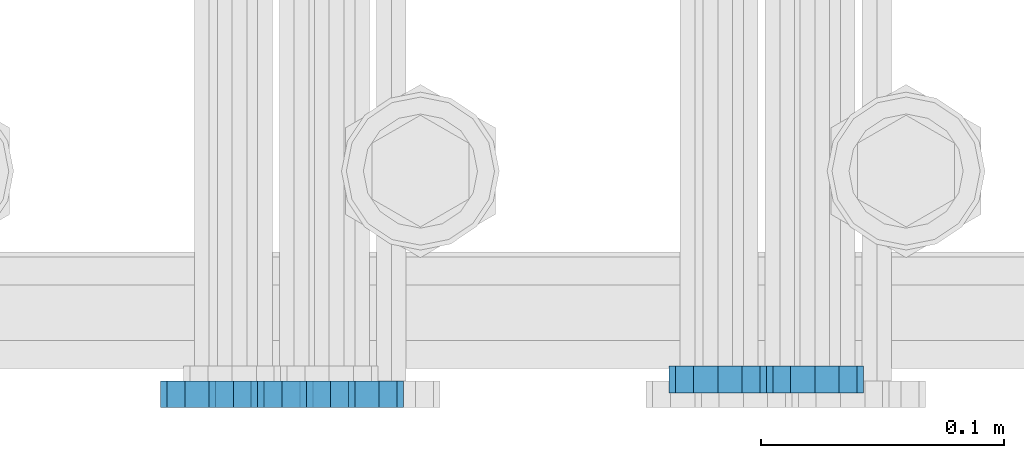
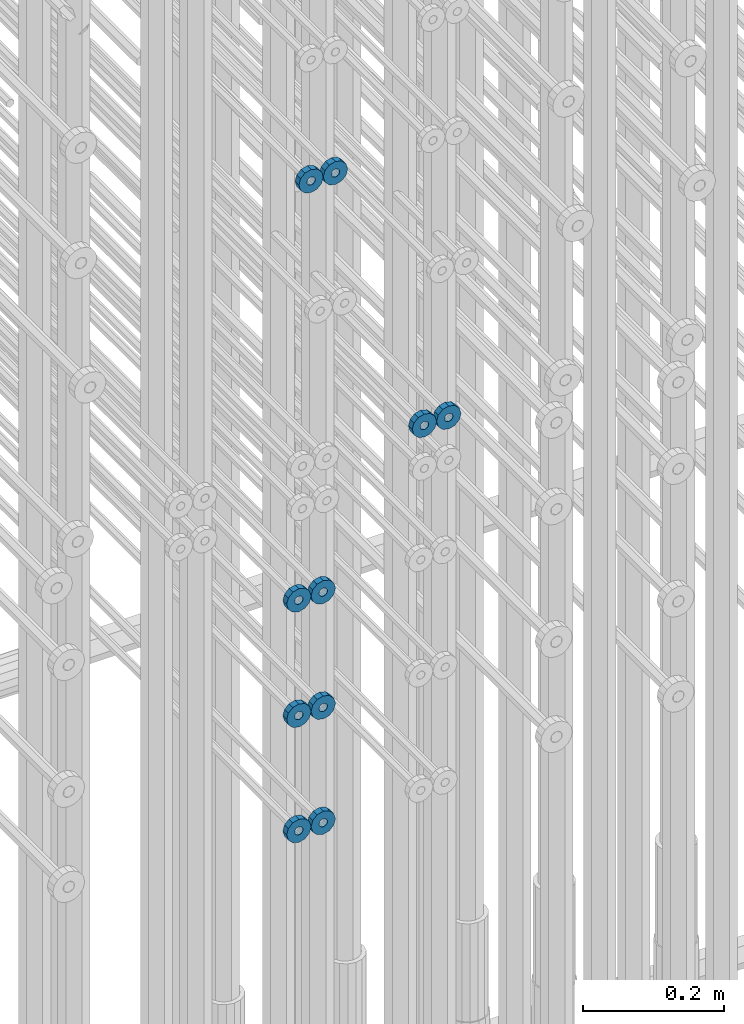
# One storey, part 127 of 177: 10 beams.
"""IFC2X3 building model written with IfcOpenShell, lengths in millimetres."""

from ifc_helpers import new_model, si_unit, frame, origin_with_axes, place, context, subcontext, project, spatial, faceted_brep, material, type_object, element, save


model = new_model("IFC2X3")

# Units and contexts
model_context_1 = context("Model", 3, precision=1e-05, world=origin_with_axes())
model_context_2 = context("Model", 3, precision=1e-05, world=origin_with_axes())
body_context = subcontext(model_context_2, "Body", "Model", "MODEL_VIEW")
ifc_project = project(units=[si_unit("LENGTHUNIT", "METRE", prefix="MILLI"), si_unit("AREAUNIT", "SQUARE_METRE"), si_unit("VOLUMEUNIT", "CUBIC_METRE"), si_unit("MASSUNIT", "GRAM", prefix="KILO"), si_unit("TIMEUNIT", "SECOND"), si_unit("PLANEANGLEUNIT", "RADIAN"), si_unit("SOLIDANGLEUNIT", "STERADIAN"), si_unit("THERMODYNAMICTEMPERATUREUNIT", "DEGREE_CELSIUS"), si_unit("LUMINOUSINTENSITYUNIT", "LUMEN")], contexts=[model_context_1])

# Site, building, storey
site_placement = place(None, origin_with_axes())
site = spatial("IfcSite", under=ifc_project, at=site_placement, CompositionType="ELEMENT")
building_placement = place(site_placement, origin_with_axes())
building = spatial("IfcBuilding", under=site, at=building_placement, Name="Undefined", CompositionType="ELEMENT")
storey_placement = place(building_placement, origin_with_axes())
storey = spatial("IfcBuildingStorey", under=building, at=storey_placement, Name="Undefined", CompositionType="ELEMENT", Elevation=0.0)

# Beams
ifc_material = material(Name="STEEL/Steel_Undefined")
beam_type = type_object("IfcBeamType", PredefinedType="NOTDEFINED")
beam_1_placement = place(storey_placement, frame((2031896.44711753, 6205077.04588021, 20865.9768110314), z_axis=(0.0, 0.0, 1.0), x_axis=(0.0, -1.0, 0.0)))
element("IfcBeam", 1, at=beam_1_placement, inside=storey, type_object=beam_type, material=ifc_material, context=body_context, shape_type="Brep", body=[
    faceted_brep([(-3.63797880709171e-12, -7.0, -2.3283064365387e-10), (-8.62348444298797e-13, -6.06217782649107, 3.5), (10.9999999999964, -6.06217782665044, 3.49999999976717), (10.9999999999964, -7.0, -2.3283064365387e-10), (-3.63797880709171e-12, -3.5, 6.06217782618478), (11.0, -3.5, 6.06217782618478), (-1.72469688859759e-12, 0.0, 7.0), (11.0, 0.0, 6.99999999976717), (-3.63797880709171e-12, 3.5, 6.06217782618478), (11.0, 3.5, 6.06217782618478), (-8.62348444298795e-13, 6.06217782649107, 3.5), (10.9999999999964, 6.06217782665044, 3.49999999976717), (-3.63797880709171e-12, 7.0, -2.3283064365387e-10), (10.9999999999964, 7.0, -2.3283064365387e-10), (8.62348444298797e-13, 6.06217782649107, -3.5), (10.9999999999964, 6.06217782665044, -3.50000000023283), (-3.63797880709171e-12, 3.5, -6.06217782665044), (10.9999999999964, 3.5, -6.06217782665044), (1.72469688859759e-12, -2.72004641033163e-15, -7.0), (10.9999999999964, 0.0, -7.00000000023283), (-3.63797880709171e-12, -3.5, -6.06217782665044), (10.9999999999964, -3.5, -6.06217782665044), (8.62348444298796e-13, -6.06217782649107, -3.5), (10.9999999999964, -6.06217782665044, -3.50000000023283), (0.0, -20.0000000009313, 0.0), (0.0, -17.320508075878, -10.0), (10.9999999999964, -17.320508075878, -10.0000000002328), (10.9999999999964, -20.0, -2.3283064365387e-10), (0.0, -10.0000000009313, -17.3205080756452), (11.0, -10.0, -17.320508075878), (0.0, -1.86264514923096e-09, -19.9999999998836), (10.9999999999964, 0.0, -20.0000000002328), (0.0, 9.99999999906868, -17.3205080755288), (11.0, 10.0, -17.320508075878), (0.0, 17.320508075878, -10.0), (10.9999999999964, 17.320508075878, -10.0000000002328), (0.0, 19.9999999990687, 0.0), (10.9999999999964, 20.0, -2.3283064365387e-10), (0.0, 17.3205080740154, 10.0), (11.0, 17.320508075878, 9.99999999976717), (0.0, 9.99999999906868, 17.3205080757616), (10.9999999999964, 10.0, 17.3205080754124), (0.0, 0.0, 20.0000000001164), (10.9999999999964, 0.0, 19.9999999997672), (0.0, -10.0000000009313, 17.3205080757616), (10.9999999999964, -10.0, 17.3205080754124), (0.0, -17.3205080777407, 10.0000000001164), (11.0, -17.320508075878, 9.99999999976717)], [[[0, 1, 2, 3]], [[1, 4, 5, 2]], [[4, 6, 7, 5]], [[6, 8, 9, 7]], [[8, 10, 11, 9]], [[10, 12, 13, 11]], [[12, 14, 15, 13]], [[14, 16, 17, 15]], [[16, 18, 19, 17]], [[18, 20, 21, 19]], [[20, 22, 23, 21]], [[22, 0, 3, 23]], [[24, 25, 26, 27]], [[25, 28, 29, 26]], [[28, 30, 31, 29]], [[30, 32, 33, 31]], [[32, 34, 35, 33]], [[34, 36, 37, 35]], [[36, 38, 39, 37]], [[38, 40, 41, 39]], [[40, 42, 43, 41]], [[42, 44, 45, 43]], [[44, 46, 47, 45]], [[46, 24, 27, 47]], [[29, 31, 33, 35, 37, 39, 41, 43, 45, 47, 27, 26], [5, 7, 9, 11, 13, 15, 17, 19, 21, 23, 3, 2]], [[46, 44, 42, 40, 38, 36, 34, 32, 30, 28, 25, 24], [22, 20, 18, 16, 14, 12, 10, 8, 6, 4, 1, 0]]]),
])
beam_2_placement = place(storey_placement, frame((2031936.43711754, 6205077.04588021, 20865.9768110316), z_axis=(0.0, 0.0, 1.0), x_axis=(0.0, -1.0, 0.0)))
element("IfcBeam", 2, at=beam_2_placement, inside=storey, type_object=beam_type, material=ifc_material, context=body_context, shape_type="Brep", body=[
    faceted_brep([(-3.63797880709171e-12, -7.0, -2.3283064365387e-10), (-8.62348444298797e-13, -6.06217782649107, 3.5), (10.9999999999964, -6.06217782665044, 3.49999999976717), (10.9999999999964, -7.0, -2.3283064365387e-10), (-3.63797880709171e-12, -3.5, 6.06217782618478), (11.0, -3.5, 6.06217782618478), (-1.72469688859759e-12, 0.0, 7.0), (11.0, 0.0, 6.99999999976717), (-3.63797880709171e-12, 3.5, 6.06217782618478), (11.0, 3.5, 6.06217782618478), (-8.62348444298795e-13, 6.06217782649107, 3.5), (10.9999999999964, 6.06217782665044, 3.49999999976717), (-3.63797880709171e-12, 7.0, -2.3283064365387e-10), (10.9999999999964, 7.0, -2.3283064365387e-10), (8.62348444298797e-13, 6.06217782649107, -3.5), (10.9999999999964, 6.06217782665044, -3.50000000023283), (-3.63797880709171e-12, 3.5, -6.06217782665044), (10.9999999999964, 3.5, -6.06217782665044), (1.72469688859759e-12, -2.72004641033163e-15, -7.0), (10.9999999999964, 0.0, -7.00000000023283), (-3.63797880709171e-12, -3.5, -6.06217782665044), (10.9999999999964, -3.5, -6.06217782665044), (8.62348444298796e-13, -6.06217782649107, -3.5), (10.9999999999964, -6.06217782665044, -3.50000000023283), (0.0, -20.0000000009313, 0.0), (0.0, -17.320508075878, -10.0), (10.9999999999964, -17.320508075878, -10.0000000002328), (10.9999999999964, -20.0, -2.3283064365387e-10), (0.0, -10.0000000009313, -17.3205080756452), (11.0, -10.0, -17.320508075878), (0.0, -1.86264514923096e-09, -19.9999999998836), (10.9999999999964, 0.0, -20.0000000002328), (0.0, 9.99999999906868, -17.3205080755288), (11.0, 10.0, -17.320508075878), (0.0, 17.320508075878, -10.0), (10.9999999999964, 17.320508075878, -10.0000000002328), (0.0, 19.9999999990687, 0.0), (10.9999999999964, 20.0, -2.3283064365387e-10), (0.0, 17.3205080740154, 10.0), (11.0, 17.320508075878, 9.99999999976717), (0.0, 9.99999999906868, 17.3205080757616), (10.9999999999964, 10.0, 17.3205080754124), (0.0, 0.0, 20.0000000001164), (10.9999999999964, 0.0, 19.9999999997672), (0.0, -10.0000000009313, 17.3205080757616), (10.9999999999964, -10.0, 17.3205080754124), (0.0, -17.3205080777407, 10.0000000001164), (11.0, -17.320508075878, 9.99999999976717)], [[[0, 1, 2, 3]], [[1, 4, 5, 2]], [[4, 6, 7, 5]], [[6, 8, 9, 7]], [[8, 10, 11, 9]], [[10, 12, 13, 11]], [[12, 14, 15, 13]], [[14, 16, 17, 15]], [[16, 18, 19, 17]], [[18, 20, 21, 19]], [[20, 22, 23, 21]], [[22, 0, 3, 23]], [[24, 25, 26, 27]], [[25, 28, 29, 26]], [[28, 30, 31, 29]], [[30, 32, 33, 31]], [[32, 34, 35, 33]], [[34, 36, 37, 35]], [[36, 38, 39, 37]], [[38, 40, 41, 39]], [[40, 42, 43, 41]], [[42, 44, 45, 43]], [[44, 46, 47, 45]], [[46, 24, 27, 47]], [[29, 31, 33, 35, 37, 39, 41, 43, 45, 47, 27, 26], [5, 7, 9, 11, 13, 15, 17, 19, 21, 23, 3, 2]], [[46, 44, 42, 40, 38, 36, 34, 32, 30, 28, 25, 24], [22, 20, 18, 16, 14, 12, 10, 8, 6, 4, 1, 0]]]),
])
beam_3_placement = place(storey_placement, frame((2031746.99847313, 6205070.98588033, 21359.9868114202), z_axis=(0.0, 0.0, -1.0), x_axis=(0.0, -1.0, 0.0)))
element("IfcBeam", 3, at=beam_3_placement, inside=storey, type_object=beam_type, material=ifc_material, context=body_context, shape_type="Brep", body=[
    faceted_brep([(-3.63797880709171e-12, -7.0, -2.3283064365387e-10), (-8.62348444298797e-13, -6.06217782649107, 3.5), (10.9999999999964, -6.06217782665044, 3.49999999976717), (10.9999999999964, -7.0, -2.3283064365387e-10), (-3.63797880709171e-12, -3.5, 6.06217782618478), (11.0, -3.5, 6.06217782618478), (-1.72469688859759e-12, 0.0, 7.0), (11.0, 0.0, 6.99999999976717), (-3.63797880709171e-12, 3.5, 6.06217782618478), (11.0, 3.5, 6.06217782618478), (-8.62348444298795e-13, 6.06217782649107, 3.5), (10.9999999999964, 6.06217782665044, 3.49999999976717), (-3.63797880709171e-12, 7.0, -2.3283064365387e-10), (10.9999999999964, 7.0, -2.3283064365387e-10), (8.62348444298797e-13, 6.06217782649107, -3.5), (10.9999999999964, 6.06217782665044, -3.50000000023283), (-3.63797880709171e-12, 3.5, -6.06217782665044), (10.9999999999964, 3.5, -6.06217782665044), (1.72469688859759e-12, -2.72004641033163e-15, -7.0), (10.9999999999964, 0.0, -7.00000000023283), (-3.63797880709171e-12, -3.5, -6.06217782665044), (10.9999999999964, -3.5, -6.06217782665044), (8.62348444298796e-13, -6.06217782649107, -3.5), (10.9999999999964, -6.06217782665044, -3.50000000023283), (0.0, -20.0000000009313, 0.0), (0.0, -17.320508075878, -10.0), (10.9999999999964, -17.320508075878, -10.0000000002328), (10.9999999999964, -20.0, -2.3283064365387e-10), (0.0, -10.0000000009313, -17.3205080756452), (11.0, -10.0, -17.320508075878), (0.0, -1.86264514923096e-09, -19.9999999998836), (10.9999999999964, 0.0, -20.0000000002328), (0.0, 9.99999999906868, -17.3205080755288), (11.0, 10.0, -17.320508075878), (0.0, 17.320508075878, -10.0), (10.9999999999964, 17.320508075878, -10.0000000002328), (0.0, 19.9999999990687, 0.0), (10.9999999999964, 20.0, -2.3283064365387e-10), (0.0, 17.3205080740154, 10.0), (11.0, 17.320508075878, 9.99999999976717), (0.0, 9.99999999906868, 17.3205080757616), (10.9999999999964, 10.0, 17.3205080754124), (0.0, 0.0, 20.0000000001164), (10.9999999999964, 0.0, 19.9999999997672), (0.0, -10.0000000009313, 17.3205080757616), (10.9999999999964, -10.0, 17.3205080754124), (0.0, -17.3205080777407, 10.0000000001164), (11.0, -17.320508075878, 9.99999999976717)], [[[0, 1, 2, 3]], [[1, 4, 5, 2]], [[4, 6, 7, 5]], [[6, 8, 9, 7]], [[8, 10, 11, 9]], [[10, 12, 13, 11]], [[12, 14, 15, 13]], [[14, 16, 17, 15]], [[16, 18, 19, 17]], [[18, 20, 21, 19]], [[20, 22, 23, 21]], [[22, 0, 3, 23]], [[24, 25, 26, 27]], [[25, 28, 29, 26]], [[28, 30, 31, 29]], [[30, 32, 33, 31]], [[32, 34, 35, 33]], [[34, 36, 37, 35]], [[36, 38, 39, 37]], [[38, 40, 41, 39]], [[40, 42, 43, 41]], [[42, 44, 45, 43]], [[44, 46, 47, 45]], [[46, 24, 27, 47]], [[29, 31, 33, 35, 37, 39, 41, 43, 45, 47, 27, 26], [5, 7, 9, 11, 13, 15, 17, 19, 21, 23, 3, 2]], [[46, 44, 42, 40, 38, 36, 34, 32, 30, 28, 25, 24], [22, 20, 18, 16, 14, 12, 10, 8, 6, 4, 1, 0]]]),
])
beam_4_placement = place(storey_placement, frame((2031706.99847313, 6205070.98588033, 21359.9868114202), z_axis=(0.0, 0.0, -1.0), x_axis=(0.0, -1.0, 0.0)))
element("IfcBeam", 4, at=beam_4_placement, inside=storey, type_object=beam_type, material=ifc_material, context=body_context, shape_type="Brep", body=[
    faceted_brep([(-3.63797880709171e-12, -7.0, -2.3283064365387e-10), (-8.62348444298797e-13, -6.06217782649107, 3.5), (10.9999999999964, -6.06217782665044, 3.49999999976717), (10.9999999999964, -7.0, -2.3283064365387e-10), (-3.63797880709171e-12, -3.5, 6.06217782618478), (11.0, -3.5, 6.06217782618478), (-1.72469688859759e-12, 0.0, 7.0), (11.0, 0.0, 6.99999999976717), (-3.63797880709171e-12, 3.5, 6.06217782618478), (11.0, 3.5, 6.06217782618478), (-8.62348444298795e-13, 6.06217782649107, 3.5), (10.9999999999964, 6.06217782665044, 3.49999999976717), (-3.63797880709171e-12, 7.0, -2.3283064365387e-10), (10.9999999999964, 7.0, -2.3283064365387e-10), (8.62348444298797e-13, 6.06217782649107, -3.5), (10.9999999999964, 6.06217782665044, -3.50000000023283), (-3.63797880709171e-12, 3.5, -6.06217782665044), (10.9999999999964, 3.5, -6.06217782665044), (1.72469688859759e-12, -2.72004641033163e-15, -7.0), (10.9999999999964, 0.0, -7.00000000023283), (-3.63797880709171e-12, -3.5, -6.06217782665044), (10.9999999999964, -3.5, -6.06217782665044), (8.62348444298796e-13, -6.06217782649107, -3.5), (10.9999999999964, -6.06217782665044, -3.50000000023283), (0.0, -20.0000000009313, 0.0), (0.0, -17.320508075878, -10.0), (10.9999999999964, -17.320508075878, -10.0000000002328), (10.9999999999964, -20.0, -2.3283064365387e-10), (0.0, -10.0000000009313, -17.3205080756452), (11.0, -10.0, -17.320508075878), (0.0, -1.86264514923096e-09, -19.9999999998836), (10.9999999999964, 0.0, -20.0000000002328), (0.0, 9.99999999906868, -17.3205080755288), (11.0, 10.0, -17.320508075878), (0.0, 17.320508075878, -10.0), (10.9999999999964, 17.320508075878, -10.0000000002328), (0.0, 19.9999999990687, 0.0), (10.9999999999964, 20.0, -2.3283064365387e-10), (0.0, 17.3205080740154, 10.0), (11.0, 17.320508075878, 9.99999999976717), (0.0, 9.99999999906868, 17.3205080757616), (10.9999999999964, 10.0, 17.3205080754124), (0.0, 0.0, 20.0000000001164), (10.9999999999964, 0.0, 19.9999999997672), (0.0, -10.0000000009313, 17.3205080757616), (10.9999999999964, -10.0, 17.3205080754124), (0.0, -17.3205080777407, 10.0000000001164), (11.0, -17.320508075878, 9.99999999976717)], [[[0, 1, 2, 3]], [[1, 4, 5, 2]], [[4, 6, 7, 5]], [[6, 8, 9, 7]], [[8, 10, 11, 9]], [[10, 12, 13, 11]], [[12, 14, 15, 13]], [[14, 16, 17, 15]], [[16, 18, 19, 17]], [[18, 20, 21, 19]], [[20, 22, 23, 21]], [[22, 0, 3, 23]], [[24, 25, 26, 27]], [[25, 28, 29, 26]], [[28, 30, 31, 29]], [[30, 32, 33, 31]], [[32, 34, 35, 33]], [[34, 36, 37, 35]], [[36, 38, 39, 37]], [[38, 40, 41, 39]], [[40, 42, 43, 41]], [[42, 44, 45, 43]], [[44, 46, 47, 45]], [[46, 24, 27, 47]], [[29, 31, 33, 35, 37, 39, 41, 43, 45, 47, 27, 26], [5, 7, 9, 11, 13, 15, 17, 19, 21, 23, 3, 2]], [[46, 44, 42, 40, 38, 36, 34, 32, 30, 28, 25, 24], [22, 20, 18, 16, 14, 12, 10, 8, 6, 4, 1, 0]]]),
])
beam_5_placement = place(storey_placement, frame((2031726.99847313, 6205070.98588034, 20639.9868114202), z_axis=(0.0, 0.0, -1.0), x_axis=(0.0, -1.0, 0.0)))
element("IfcBeam", 5, at=beam_5_placement, inside=storey, type_object=beam_type, material=ifc_material, context=body_context, shape_type="Brep", body=[
    faceted_brep([(-3.63797880709171e-12, -7.0, -2.3283064365387e-10), (-8.62348444298797e-13, -6.06217782649107, 3.5), (10.9999999999964, -6.06217782665044, 3.49999999976717), (10.9999999999964, -7.0, -2.3283064365387e-10), (-3.63797880709171e-12, -3.5, 6.06217782618478), (11.0, -3.5, 6.06217782618478), (-1.72469688859759e-12, 0.0, 7.0), (11.0, 0.0, 6.99999999976717), (-3.63797880709171e-12, 3.5, 6.06217782618478), (11.0, 3.5, 6.06217782618478), (-8.62348444298795e-13, 6.06217782649107, 3.5), (10.9999999999964, 6.06217782665044, 3.49999999976717), (-3.63797880709171e-12, 7.0, -2.3283064365387e-10), (10.9999999999964, 7.0, -2.3283064365387e-10), (8.62348444298797e-13, 6.06217782649107, -3.5), (10.9999999999964, 6.06217782665044, -3.50000000023283), (-3.63797880709171e-12, 3.5, -6.06217782665044), (10.9999999999964, 3.5, -6.06217782665044), (1.72469688859759e-12, -2.72004641033163e-15, -7.0), (10.9999999999964, 0.0, -7.00000000023283), (-3.63797880709171e-12, -3.5, -6.06217782665044), (10.9999999999964, -3.5, -6.06217782665044), (8.62348444298796e-13, -6.06217782649107, -3.5), (10.9999999999964, -6.06217782665044, -3.50000000023283), (0.0, -20.0000000009313, 0.0), (0.0, -17.320508075878, -10.0), (10.9999999999964, -17.320508075878, -10.0000000002328), (10.9999999999964, -20.0, -2.3283064365387e-10), (0.0, -10.0000000009313, -17.3205080756452), (11.0, -10.0, -17.320508075878), (0.0, -1.86264514923096e-09, -19.9999999998836), (10.9999999999964, 0.0, -20.0000000002328), (0.0, 9.99999999906868, -17.3205080755288), (11.0, 10.0, -17.320508075878), (0.0, 17.320508075878, -10.0), (10.9999999999964, 17.320508075878, -10.0000000002328), (0.0, 19.9999999990687, 0.0), (10.9999999999964, 20.0, -2.3283064365387e-10), (0.0, 17.3205080740154, 10.0), (11.0, 17.320508075878, 9.99999999976717), (0.0, 9.99999999906868, 17.3205080757616), (10.9999999999964, 10.0, 17.3205080754124), (0.0, 0.0, 20.0000000001164), (10.9999999999964, 0.0, 19.9999999997672), (0.0, -10.0000000009313, 17.3205080757616), (10.9999999999964, -10.0, 17.3205080754124), (0.0, -17.3205080777407, 10.0000000001164), (11.0, -17.320508075878, 9.99999999976717)], [[[0, 1, 2, 3]], [[1, 4, 5, 2]], [[4, 6, 7, 5]], [[6, 8, 9, 7]], [[8, 10, 11, 9]], [[10, 12, 13, 11]], [[12, 14, 15, 13]], [[14, 16, 17, 15]], [[16, 18, 19, 17]], [[18, 20, 21, 19]], [[20, 22, 23, 21]], [[22, 0, 3, 23]], [[24, 25, 26, 27]], [[25, 28, 29, 26]], [[28, 30, 31, 29]], [[30, 32, 33, 31]], [[32, 34, 35, 33]], [[34, 36, 37, 35]], [[36, 38, 39, 37]], [[38, 40, 41, 39]], [[40, 42, 43, 41]], [[42, 44, 45, 43]], [[44, 46, 47, 45]], [[46, 24, 27, 47]], [[29, 31, 33, 35, 37, 39, 41, 43, 45, 47, 27, 26], [5, 7, 9, 11, 13, 15, 17, 19, 21, 23, 3, 2]], [[46, 44, 42, 40, 38, 36, 34, 32, 30, 28, 25, 24], [22, 20, 18, 16, 14, 12, 10, 8, 6, 4, 1, 0]]]),
])
beam_6_placement = place(storey_placement, frame((2031686.99847313, 6205070.98588034, 20639.9868114202), z_axis=(0.0, 0.0, -1.0), x_axis=(0.0, -1.0, 0.0)))
element("IfcBeam", 6, at=beam_6_placement, inside=storey, type_object=beam_type, material=ifc_material, context=body_context, shape_type="Brep", body=[
    faceted_brep([(-3.63797880709171e-12, -7.0, -2.3283064365387e-10), (-8.62348444298797e-13, -6.06217782649107, 3.5), (10.9999999999964, -6.06217782665044, 3.49999999976717), (10.9999999999964, -7.0, -2.3283064365387e-10), (-3.63797880709171e-12, -3.5, 6.06217782618478), (11.0, -3.5, 6.06217782618478), (-1.72469688859759e-12, 0.0, 7.0), (11.0, 0.0, 6.99999999976717), (-3.63797880709171e-12, 3.5, 6.06217782618478), (11.0, 3.5, 6.06217782618478), (-8.62348444298795e-13, 6.06217782649107, 3.5), (10.9999999999964, 6.06217782665044, 3.49999999976717), (-3.63797880709171e-12, 7.0, -2.3283064365387e-10), (10.9999999999964, 7.0, -2.3283064365387e-10), (8.62348444298797e-13, 6.06217782649107, -3.5), (10.9999999999964, 6.06217782665044, -3.50000000023283), (-3.63797880709171e-12, 3.5, -6.06217782665044), (10.9999999999964, 3.5, -6.06217782665044), (1.72469688859759e-12, -2.72004641033163e-15, -7.0), (10.9999999999964, 0.0, -7.00000000023283), (-3.63797880709171e-12, -3.5, -6.06217782665044), (10.9999999999964, -3.5, -6.06217782665044), (8.62348444298796e-13, -6.06217782649107, -3.5), (10.9999999999964, -6.06217782665044, -3.50000000023283), (0.0, -20.0000000009313, 0.0), (0.0, -17.320508075878, -10.0), (10.9999999999964, -17.320508075878, -10.0000000002328), (10.9999999999964, -20.0, -2.3283064365387e-10), (0.0, -10.0000000009313, -17.3205080756452), (11.0, -10.0, -17.320508075878), (0.0, -1.86264514923096e-09, -19.9999999998836), (10.9999999999964, 0.0, -20.0000000002328), (0.0, 9.99999999906868, -17.3205080755288), (11.0, 10.0, -17.320508075878), (0.0, 17.320508075878, -10.0), (10.9999999999964, 17.320508075878, -10.0000000002328), (0.0, 19.9999999990687, 0.0), (10.9999999999964, 20.0, -2.3283064365387e-10), (0.0, 17.3205080740154, 10.0), (11.0, 17.320508075878, 9.99999999976717), (0.0, 9.99999999906868, 17.3205080757616), (10.9999999999964, 10.0, 17.3205080754124), (0.0, 0.0, 20.0000000001164), (10.9999999999964, 0.0, 19.9999999997672), (0.0, -10.0000000009313, 17.3205080757616), (10.9999999999964, -10.0, 17.3205080754124), (0.0, -17.3205080777407, 10.0000000001164), (11.0, -17.320508075878, 9.99999999976717)], [[[0, 1, 2, 3]], [[1, 4, 5, 2]], [[4, 6, 7, 5]], [[6, 8, 9, 7]], [[8, 10, 11, 9]], [[10, 12, 13, 11]], [[12, 14, 15, 13]], [[14, 16, 17, 15]], [[16, 18, 19, 17]], [[18, 20, 21, 19]], [[20, 22, 23, 21]], [[22, 0, 3, 23]], [[24, 25, 26, 27]], [[25, 28, 29, 26]], [[28, 30, 31, 29]], [[30, 32, 33, 31]], [[32, 34, 35, 33]], [[34, 36, 37, 35]], [[36, 38, 39, 37]], [[38, 40, 41, 39]], [[40, 42, 43, 41]], [[42, 44, 45, 43]], [[44, 46, 47, 45]], [[46, 24, 27, 47]], [[29, 31, 33, 35, 37, 39, 41, 43, 45, 47, 27, 26], [5, 7, 9, 11, 13, 15, 17, 19, 21, 23, 3, 2]], [[46, 44, 42, 40, 38, 36, 34, 32, 30, 28, 25, 24], [22, 20, 18, 16, 14, 12, 10, 8, 6, 4, 1, 0]]]),
])
beam_7_placement = place(storey_placement, frame((2031726.99847313, 6205070.98588034, 20439.9868114202), z_axis=(0.0, 0.0, -1.0), x_axis=(0.0, -1.0, 0.0)))
element("IfcBeam", 7, at=beam_7_placement, inside=storey, type_object=beam_type, material=ifc_material, context=body_context, shape_type="Brep", body=[
    faceted_brep([(-3.63797880709171e-12, -7.0, -2.3283064365387e-10), (-8.62348444298797e-13, -6.06217782649107, 3.5), (10.9999999999964, -6.06217782665044, 3.49999999976717), (10.9999999999964, -7.0, -2.3283064365387e-10), (-3.63797880709171e-12, -3.5, 6.06217782618478), (11.0, -3.5, 6.06217782618478), (-1.72469688859759e-12, 0.0, 7.0), (11.0, 0.0, 6.99999999976717), (-3.63797880709171e-12, 3.5, 6.06217782618478), (11.0, 3.5, 6.06217782618478), (-8.62348444298795e-13, 6.06217782649107, 3.5), (10.9999999999964, 6.06217782665044, 3.49999999976717), (-3.63797880709171e-12, 7.0, -2.3283064365387e-10), (10.9999999999964, 7.0, -2.3283064365387e-10), (8.62348444298797e-13, 6.06217782649107, -3.5), (10.9999999999964, 6.06217782665044, -3.50000000023283), (-3.63797880709171e-12, 3.5, -6.06217782665044), (10.9999999999964, 3.5, -6.06217782665044), (1.72469688859759e-12, -2.72004641033163e-15, -7.0), (10.9999999999964, 0.0, -7.00000000023283), (-3.63797880709171e-12, -3.5, -6.06217782665044), (10.9999999999964, -3.5, -6.06217782665044), (8.62348444298796e-13, -6.06217782649107, -3.5), (10.9999999999964, -6.06217782665044, -3.50000000023283), (0.0, -20.0000000009313, 0.0), (0.0, -17.320508075878, -10.0), (10.9999999999964, -17.320508075878, -10.0000000002328), (10.9999999999964, -20.0, -2.3283064365387e-10), (0.0, -10.0000000009313, -17.3205080756452), (11.0, -10.0, -17.320508075878), (0.0, -1.86264514923096e-09, -19.9999999998836), (10.9999999999964, 0.0, -20.0000000002328), (0.0, 9.99999999906868, -17.3205080755288), (11.0, 10.0, -17.320508075878), (0.0, 17.320508075878, -10.0), (10.9999999999964, 17.320508075878, -10.0000000002328), (0.0, 19.9999999990687, 0.0), (10.9999999999964, 20.0, -2.3283064365387e-10), (0.0, 17.3205080740154, 10.0), (11.0, 17.320508075878, 9.99999999976717), (0.0, 9.99999999906868, 17.3205080757616), (10.9999999999964, 10.0, 17.3205080754124), (0.0, 0.0, 20.0000000001164), (10.9999999999964, 0.0, 19.9999999997672), (0.0, -10.0000000009313, 17.3205080757616), (10.9999999999964, -10.0, 17.3205080754124), (0.0, -17.3205080777407, 10.0000000001164), (11.0, -17.320508075878, 9.99999999976717)], [[[0, 1, 2, 3]], [[1, 4, 5, 2]], [[4, 6, 7, 5]], [[6, 8, 9, 7]], [[8, 10, 11, 9]], [[10, 12, 13, 11]], [[12, 14, 15, 13]], [[14, 16, 17, 15]], [[16, 18, 19, 17]], [[18, 20, 21, 19]], [[20, 22, 23, 21]], [[22, 0, 3, 23]], [[24, 25, 26, 27]], [[25, 28, 29, 26]], [[28, 30, 31, 29]], [[30, 32, 33, 31]], [[32, 34, 35, 33]], [[34, 36, 37, 35]], [[36, 38, 39, 37]], [[38, 40, 41, 39]], [[40, 42, 43, 41]], [[42, 44, 45, 43]], [[44, 46, 47, 45]], [[46, 24, 27, 47]], [[29, 31, 33, 35, 37, 39, 41, 43, 45, 47, 27, 26], [5, 7, 9, 11, 13, 15, 17, 19, 21, 23, 3, 2]], [[46, 44, 42, 40, 38, 36, 34, 32, 30, 28, 25, 24], [22, 20, 18, 16, 14, 12, 10, 8, 6, 4, 1, 0]]]),
])
beam_8_placement = place(storey_placement, frame((2031686.99847313, 6205070.98588034, 20439.9868114202), z_axis=(0.0, 0.0, -1.0), x_axis=(0.0, -1.0, 0.0)))
element("IfcBeam", 8, at=beam_8_placement, inside=storey, type_object=beam_type, material=ifc_material, context=body_context, shape_type="Brep", body=[
    faceted_brep([(-3.63797880709171e-12, -7.0, -2.3283064365387e-10), (-8.62348444298797e-13, -6.06217782649107, 3.5), (10.9999999999964, -6.06217782665044, 3.49999999976717), (10.9999999999964, -7.0, -2.3283064365387e-10), (-3.63797880709171e-12, -3.5, 6.06217782618478), (11.0, -3.5, 6.06217782618478), (-1.72469688859759e-12, 0.0, 7.0), (11.0, 0.0, 6.99999999976717), (-3.63797880709171e-12, 3.5, 6.06217782618478), (11.0, 3.5, 6.06217782618478), (-8.62348444298795e-13, 6.06217782649107, 3.5), (10.9999999999964, 6.06217782665044, 3.49999999976717), (-3.63797880709171e-12, 7.0, -2.3283064365387e-10), (10.9999999999964, 7.0, -2.3283064365387e-10), (8.62348444298797e-13, 6.06217782649107, -3.5), (10.9999999999964, 6.06217782665044, -3.50000000023283), (-3.63797880709171e-12, 3.5, -6.06217782665044), (10.9999999999964, 3.5, -6.06217782665044), (1.72469688859759e-12, -2.72004641033163e-15, -7.0), (10.9999999999964, 0.0, -7.00000000023283), (-3.63797880709171e-12, -3.5, -6.06217782665044), (10.9999999999964, -3.5, -6.06217782665044), (8.62348444298796e-13, -6.06217782649107, -3.5), (10.9999999999964, -6.06217782665044, -3.50000000023283), (0.0, -20.0000000009313, 0.0), (0.0, -17.320508075878, -10.0), (10.9999999999964, -17.320508075878, -10.0000000002328), (10.9999999999964, -20.0, -2.3283064365387e-10), (0.0, -10.0000000009313, -17.3205080756452), (11.0, -10.0, -17.320508075878), (0.0, -1.86264514923096e-09, -19.9999999998836), (10.9999999999964, 0.0, -20.0000000002328), (0.0, 9.99999999906868, -17.3205080755288), (11.0, 10.0, -17.320508075878), (0.0, 17.320508075878, -10.0), (10.9999999999964, 17.320508075878, -10.0000000002328), (0.0, 19.9999999990687, 0.0), (10.9999999999964, 20.0, -2.3283064365387e-10), (0.0, 17.3205080740154, 10.0), (11.0, 17.320508075878, 9.99999999976717), (0.0, 9.99999999906868, 17.3205080757616), (10.9999999999964, 10.0, 17.3205080754124), (0.0, 0.0, 20.0000000001164), (10.9999999999964, 0.0, 19.9999999997672), (0.0, -10.0000000009313, 17.3205080757616), (10.9999999999964, -10.0, 17.3205080754124), (0.0, -17.3205080777407, 10.0000000001164), (11.0, -17.320508075878, 9.99999999976717)], [[[0, 1, 2, 3]], [[1, 4, 5, 2]], [[4, 6, 7, 5]], [[6, 8, 9, 7]], [[8, 10, 11, 9]], [[10, 12, 13, 11]], [[12, 14, 15, 13]], [[14, 16, 17, 15]], [[16, 18, 19, 17]], [[18, 20, 21, 19]], [[20, 22, 23, 21]], [[22, 0, 3, 23]], [[24, 25, 26, 27]], [[25, 28, 29, 26]], [[28, 30, 31, 29]], [[30, 32, 33, 31]], [[32, 34, 35, 33]], [[34, 36, 37, 35]], [[36, 38, 39, 37]], [[38, 40, 41, 39]], [[40, 42, 43, 41]], [[42, 44, 45, 43]], [[44, 46, 47, 45]], [[46, 24, 27, 47]], [[29, 31, 33, 35, 37, 39, 41, 43, 45, 47, 27, 26], [5, 7, 9, 11, 13, 15, 17, 19, 21, 23, 3, 2]], [[46, 44, 42, 40, 38, 36, 34, 32, 30, 28, 25, 24], [22, 20, 18, 16, 14, 12, 10, 8, 6, 4, 1, 0]]]),
])
beam_9_placement = place(storey_placement, frame((2031726.99847313, 6205070.98588034, 20239.9868114202), z_axis=(0.0, 0.0, -1.0), x_axis=(0.0, -1.0, 0.0)))
element("IfcBeam", 9, at=beam_9_placement, inside=storey, type_object=beam_type, material=ifc_material, context=body_context, shape_type="Brep", body=[
    faceted_brep([(-3.63797880709171e-12, -7.0, -2.3283064365387e-10), (-8.62348444298797e-13, -6.06217782649107, 3.5), (10.9999999999964, -6.06217782665044, 3.49999999976717), (10.9999999999964, -7.0, -2.3283064365387e-10), (-3.63797880709171e-12, -3.5, 6.06217782618478), (11.0, -3.5, 6.06217782618478), (-1.72469688859759e-12, 0.0, 7.0), (11.0, 0.0, 6.99999999976717), (-3.63797880709171e-12, 3.5, 6.06217782618478), (11.0, 3.5, 6.06217782618478), (-8.62348444298795e-13, 6.06217782649107, 3.5), (10.9999999999964, 6.06217782665044, 3.49999999976717), (-3.63797880709171e-12, 7.0, -2.3283064365387e-10), (10.9999999999964, 7.0, -2.3283064365387e-10), (8.62348444298797e-13, 6.06217782649107, -3.5), (10.9999999999964, 6.06217782665044, -3.50000000023283), (-3.63797880709171e-12, 3.5, -6.06217782665044), (10.9999999999964, 3.5, -6.06217782665044), (1.72469688859759e-12, -2.72004641033163e-15, -7.0), (10.9999999999964, 0.0, -7.00000000023283), (-3.63797880709171e-12, -3.5, -6.06217782665044), (10.9999999999964, -3.5, -6.06217782665044), (8.62348444298796e-13, -6.06217782649107, -3.5), (10.9999999999964, -6.06217782665044, -3.50000000023283), (0.0, -20.0000000009313, 0.0), (0.0, -17.320508075878, -10.0), (10.9999999999964, -17.320508075878, -10.0000000002328), (10.9999999999964, -20.0, -2.3283064365387e-10), (0.0, -10.0000000009313, -17.3205080756452), (11.0, -10.0, -17.320508075878), (0.0, -1.86264514923096e-09, -19.9999999998836), (10.9999999999964, 0.0, -20.0000000002328), (0.0, 9.99999999906868, -17.3205080755288), (11.0, 10.0, -17.320508075878), (0.0, 17.320508075878, -10.0), (10.9999999999964, 17.320508075878, -10.0000000002328), (0.0, 19.9999999990687, 0.0), (10.9999999999964, 20.0, -2.3283064365387e-10), (0.0, 17.3205080740154, 10.0), (11.0, 17.320508075878, 9.99999999976717), (0.0, 9.99999999906868, 17.3205080757616), (10.9999999999964, 10.0, 17.3205080754124), (0.0, 0.0, 20.0000000001164), (10.9999999999964, 0.0, 19.9999999997672), (0.0, -10.0000000009313, 17.3205080757616), (10.9999999999964, -10.0, 17.3205080754124), (0.0, -17.3205080777407, 10.0000000001164), (11.0, -17.320508075878, 9.99999999976717)], [[[0, 1, 2, 3]], [[1, 4, 5, 2]], [[4, 6, 7, 5]], [[6, 8, 9, 7]], [[8, 10, 11, 9]], [[10, 12, 13, 11]], [[12, 14, 15, 13]], [[14, 16, 17, 15]], [[16, 18, 19, 17]], [[18, 20, 21, 19]], [[20, 22, 23, 21]], [[22, 0, 3, 23]], [[24, 25, 26, 27]], [[25, 28, 29, 26]], [[28, 30, 31, 29]], [[30, 32, 33, 31]], [[32, 34, 35, 33]], [[34, 36, 37, 35]], [[36, 38, 39, 37]], [[38, 40, 41, 39]], [[40, 42, 43, 41]], [[42, 44, 45, 43]], [[44, 46, 47, 45]], [[46, 24, 27, 47]], [[29, 31, 33, 35, 37, 39, 41, 43, 45, 47, 27, 26], [5, 7, 9, 11, 13, 15, 17, 19, 21, 23, 3, 2]], [[46, 44, 42, 40, 38, 36, 34, 32, 30, 28, 25, 24], [22, 20, 18, 16, 14, 12, 10, 8, 6, 4, 1, 0]]]),
])
beam_10_placement = place(storey_placement, frame((2031686.99847313, 6205070.98588034, 20239.9868114202), z_axis=(0.0, 0.0, -1.0), x_axis=(0.0, -1.0, 0.0)))
element("IfcBeam", 10, at=beam_10_placement, inside=storey, type_object=beam_type, material=ifc_material, context=body_context, shape_type="Brep", body=[
    faceted_brep([(-3.63797880709171e-12, -7.0, -2.3283064365387e-10), (-8.62348444298797e-13, -6.06217782649107, 3.5), (10.9999999999964, -6.06217782665044, 3.49999999976717), (10.9999999999964, -7.0, -2.3283064365387e-10), (-3.63797880709171e-12, -3.5, 6.06217782618478), (11.0, -3.5, 6.06217782618478), (-1.72469688859759e-12, 0.0, 7.0), (11.0, 0.0, 6.99999999976717), (-3.63797880709171e-12, 3.5, 6.06217782618478), (11.0, 3.5, 6.06217782618478), (-8.62348444298795e-13, 6.06217782649107, 3.5), (10.9999999999964, 6.06217782665044, 3.49999999976717), (-3.63797880709171e-12, 7.0, -2.3283064365387e-10), (10.9999999999964, 7.0, -2.3283064365387e-10), (8.62348444298797e-13, 6.06217782649107, -3.5), (10.9999999999964, 6.06217782665044, -3.50000000023283), (-3.63797880709171e-12, 3.5, -6.06217782665044), (10.9999999999964, 3.5, -6.06217782665044), (1.72469688859759e-12, -2.72004641033163e-15, -7.0), (10.9999999999964, 0.0, -7.00000000023283), (-3.63797880709171e-12, -3.5, -6.06217782665044), (10.9999999999964, -3.5, -6.06217782665044), (8.62348444298796e-13, -6.06217782649107, -3.5), (10.9999999999964, -6.06217782665044, -3.50000000023283), (0.0, -20.0000000009313, 0.0), (0.0, -17.320508075878, -10.0), (10.9999999999964, -17.320508075878, -10.0000000002328), (10.9999999999964, -20.0, -2.3283064365387e-10), (0.0, -10.0000000009313, -17.3205080756452), (11.0, -10.0, -17.320508075878), (0.0, -1.86264514923096e-09, -19.9999999998836), (10.9999999999964, 0.0, -20.0000000002328), (0.0, 9.99999999906868, -17.3205080755288), (11.0, 10.0, -17.320508075878), (0.0, 17.320508075878, -10.0), (10.9999999999964, 17.320508075878, -10.0000000002328), (0.0, 19.9999999990687, 0.0), (10.9999999999964, 20.0, -2.3283064365387e-10), (0.0, 17.3205080740154, 10.0), (11.0, 17.320508075878, 9.99999999976717), (0.0, 9.99999999906868, 17.3205080757616), (10.9999999999964, 10.0, 17.3205080754124), (0.0, 0.0, 20.0000000001164), (10.9999999999964, 0.0, 19.9999999997672), (0.0, -10.0000000009313, 17.3205080757616), (10.9999999999964, -10.0, 17.3205080754124), (0.0, -17.3205080777407, 10.0000000001164), (11.0, -17.320508075878, 9.99999999976717)], [[[0, 1, 2, 3]], [[1, 4, 5, 2]], [[4, 6, 7, 5]], [[6, 8, 9, 7]], [[8, 10, 11, 9]], [[10, 12, 13, 11]], [[12, 14, 15, 13]], [[14, 16, 17, 15]], [[16, 18, 19, 17]], [[18, 20, 21, 19]], [[20, 22, 23, 21]], [[22, 0, 3, 23]], [[24, 25, 26, 27]], [[25, 28, 29, 26]], [[28, 30, 31, 29]], [[30, 32, 33, 31]], [[32, 34, 35, 33]], [[34, 36, 37, 35]], [[36, 38, 39, 37]], [[38, 40, 41, 39]], [[40, 42, 43, 41]], [[42, 44, 45, 43]], [[44, 46, 47, 45]], [[46, 24, 27, 47]], [[29, 31, 33, 35, 37, 39, 41, 43, 45, 47, 27, 26], [5, 7, 9, 11, 13, 15, 17, 19, 21, 23, 3, 2]], [[46, 44, 42, 40, 38, 36, 34, 32, 30, 28, 25, 24], [22, 20, 18, 16, 14, 12, 10, 8, 6, 4, 1, 0]]]),
])

save(model, "model.ifc")
